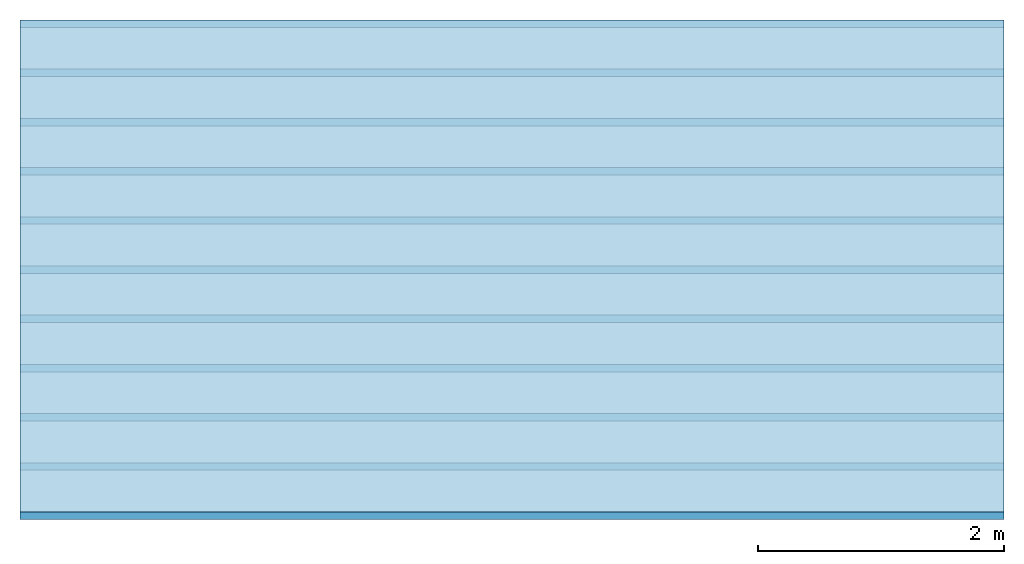
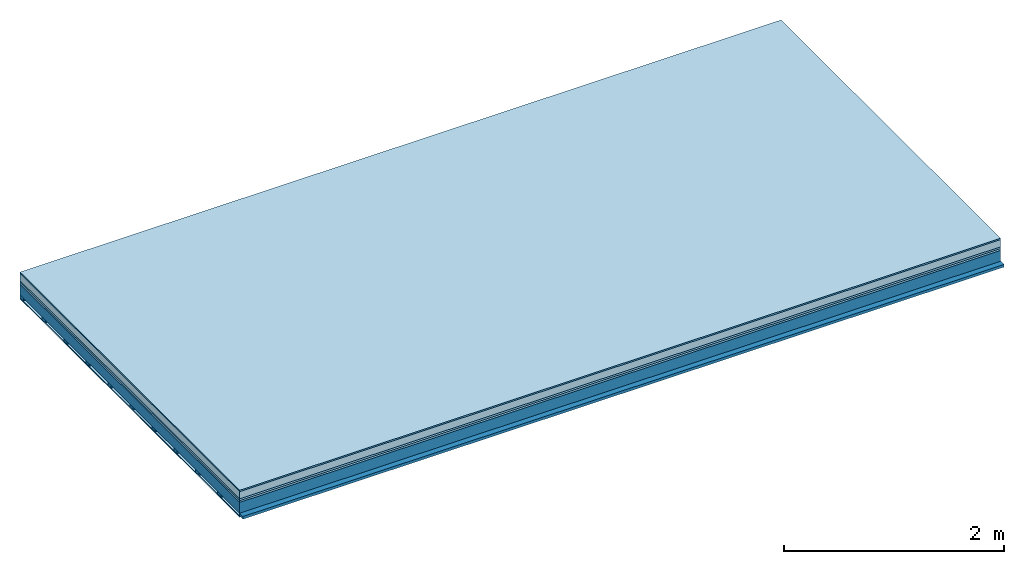
# One storey: 6 plates, 2 members, 1 element without a shape of its own.
"""IFC4 building model written with IfcOpenShell, lengths in metres."""

from ifc_helpers import new_model, si_unit, derived_unit, direction, frame, frame_2d, origin, origin_with_axes, place, context, project, spatial, rectangle, extrude, material, layer, layer_set, type_object, element, aggregate, save


model = new_model("IFC4")

# Units and contexts
plan_context = context("Plan", 3, precision=1e-05, world=origin(), true_north=direction((0.0, 1.0)))
model_context = context("Model", 3, precision=1e-05, world=origin(), true_north=direction((0.0, 1.0)))
ifc_project = project(units=[si_unit("LENGTHUNIT", "METRE"), derived_unit("SOUNDPRESSUREUNIT", [(si_unit("PRESSUREUNIT", "PASCAL", prefix="MICRO"), 0)]), si_unit("ENERGYUNIT", "JOULE", prefix="MEGA"), si_unit("MASSUNIT", "GRAM", prefix="KILO"), derived_unit("THERMALTRANSMITTANCEUNIT", [(si_unit("POWERUNIT", "WATT"), 1), (si_unit("AREAUNIT", "SQUARE_METRE"), -1), (si_unit("THERMODYNAMICTEMPERATUREUNIT", "KELVIN"), -1)]), derived_unit("AREADENSITYUNIT", [(si_unit("MASSUNIT", "GRAM", prefix="KILO"), 1), (si_unit("AREAUNIT", "SQUARE_METRE"), -1)]), derived_unit("USERDEFINED", [(si_unit("ENERGYUNIT", "JOULE", prefix="MEGA"), 1), (si_unit("AREAUNIT", "SQUARE_METRE"), -1)])], contexts=[plan_context, model_context])

# Site, building, storey
site = spatial("IfcSite", under=ifc_project)
building_placement = place(None, origin())
building = spatial("IfcBuilding", under=site, at=building_placement)
storey_placement = place(building_placement, origin())
storey = spatial("IfcBuildingStorey", under=building, at=storey_placement)

# Slab, members, plates
ifc_material_1 = material(Category="11.013")
ifc_layer_1 = layer(ifc_material_1, 0.015, Name="Flooring")
ifc_material_2 = material(Name="Cement screed", Category="04.006")
ifc_layer_2 = layer(ifc_material_2, 0.08, Name="On-material")
ifc_material_3 = material(Name="Wood fiber generic product", Category="10.009")
ifc_layer_3 = layer(ifc_material_3, 0.02, Name="Impact sound insulation")
ifc_material_4 = material(Category="10.004")
ifc_layer_4 = layer(ifc_material_4, 0.02, Name="Additional insulation")
ifc_material_5 = material(Name="no composite action")
ifc_layer_5 = layer(ifc_material_5, 0.0, Name="Bond")
ifc_layer_6 = layer(None, 0.12, Name="Supporting structure")
ifc_material_6 = material(Name="of the art")
ifc_layer_7 = layer(ifc_material_6, 0.0, Name="Bond")
ifc_layer_8 = layer(None, 0.03, Name="Battens / profiles")
ifc_material_7 = material(Name="Plasterboard type A", Category="03.008")
ifc_layer_9 = layer(ifc_material_7, 0.0125, Name="Ceiling covering 1st layer")
ifc_material_8 = material(Category="04.001")
ifc_layer_10 = layer(ifc_material_8, 0.003, Name="Surface / treatment")
ifc_layer_set = layer_set([ifc_layer_1, ifc_layer_2, ifc_layer_3, ifc_layer_4, ifc_layer_5, ifc_layer_6, ifc_layer_7, ifc_layer_8, ifc_layer_9, ifc_layer_10])
slab_type = type_object("IfcSlabType", Name="A2141", PredefinedType="NOTDEFINED", material=ifc_layer_set)
slab_placement = place(None, frame((0.0, 0.0, 0.0), z_axis=(0.0, 0.0, -1.0), x_axis=(1.0, 0.0, 0.0)))
slab = element("IfcSlab", 1, at=slab_placement, inside=storey, type_object=slab_type, material=ifc_layer_set, Name="Slab #1")
ifc_material_9 = material(Name="Solid timber panel")
member_1_placement = place(slab_placement, origin())
member_1 = element("IfcMember", 2, at=member_1_placement, material=ifc_material_9, Name="Supporting structure", context=plan_context, shape_type="SweptSolid", body=[
    extrude(rectangle(XDim=1.0, YDim=0.12, at=frame_2d((0.5, 0.06), x_axis=(1.0, 0.0))), frame((0.0, 4.0, 0.135), z_axis=(0.0, -1.0, 0.0), x_axis=(1.0, 0.0, 0.0)), (0.0, 0.0, 1.0), 4.0),
    extrude(rectangle(XDim=1.0, YDim=0.12, at=frame_2d((0.5, 0.06), x_axis=(1.0, 0.0))), frame((1.0, 4.0, 0.135), z_axis=(0.0, -1.0, 0.0), x_axis=(1.0, 0.0, 0.0)), (0.0, 0.0, 1.0), 4.0),
    extrude(rectangle(XDim=1.0, YDim=0.12, at=frame_2d((0.5, 0.06), x_axis=(1.0, 0.0))), frame((2.0, 4.0, 0.135), z_axis=(0.0, -1.0, 0.0), x_axis=(1.0, 0.0, 0.0)), (0.0, 0.0, 1.0), 4.0),
    extrude(rectangle(XDim=1.0, YDim=0.12, at=frame_2d((0.5, 0.06), x_axis=(1.0, 0.0))), frame((3.0, 4.0, 0.135), z_axis=(0.0, -1.0, 0.0), x_axis=(1.0, 0.0, 0.0)), (0.0, 0.0, 1.0), 4.0),
    extrude(rectangle(XDim=1.0, YDim=0.12, at=frame_2d((0.5, 0.06), x_axis=(1.0, 0.0))), frame((4.0, 4.0, 0.135), z_axis=(0.0, -1.0, 0.0), x_axis=(1.0, 0.0, 0.0)), (0.0, 0.0, 1.0), 4.0),
    extrude(rectangle(XDim=1.0, YDim=0.12, at=frame_2d((0.5, 0.06), x_axis=(1.0, 0.0))), frame((5.0, 4.0, 0.135), z_axis=(0.0, -1.0, 0.0), x_axis=(1.0, 0.0, 0.0)), (0.0, 0.0, 1.0), 4.0),
    extrude(rectangle(XDim=1.0, YDim=0.12, at=frame_2d((0.5, 0.06), x_axis=(1.0, 0.0))), frame((6.0, 4.0, 0.135), z_axis=(0.0, -1.0, 0.0), x_axis=(1.0, 0.0, 0.0)), (0.0, 0.0, 1.0), 4.0),
    extrude(rectangle(XDim=1.0, YDim=0.12, at=frame_2d((0.5, 0.06), x_axis=(1.0, 0.0))), frame((7.0, 4.0, 0.135), z_axis=(0.0, -1.0, 0.0), x_axis=(1.0, 0.0, 0.0)), (0.0, 0.0, 1.0), 4.0),
])
ifc_material_10 = material()
member_2_placement = place(slab_placement, origin())
member_2 = element("IfcMember", 3, at=member_2_placement, material=ifc_material_10, Name="Battens / profiles", context=plan_context, shape_type="SweptSolid", body=[
    extrude(rectangle(XDim=0.06, YDim=0.03, at=frame_2d((0.03, 0.015), x_axis=(1.0, 0.0))), frame((0.0, 0.0, 0.255), z_axis=(1.0, 0.0, 0.0), x_axis=(0.0, 1.0, 0.0)), (0.0, 0.0, 1.0), 8.0),
    extrude(rectangle(XDim=0.06, YDim=0.03, at=frame_2d((0.03, 0.015), x_axis=(1.0, 0.0))), frame((0.0, 0.4, 0.255), z_axis=(1.0, 0.0, 0.0), x_axis=(0.0, 1.0, 0.0)), (0.0, 0.0, 1.0), 8.0),
    extrude(rectangle(XDim=0.06, YDim=0.03, at=frame_2d((0.03, 0.015), x_axis=(1.0, 0.0))), frame((0.0, 0.8, 0.255), z_axis=(1.0, 0.0, 0.0), x_axis=(0.0, 1.0, 0.0)), (0.0, 0.0, 1.0), 8.0),
    extrude(rectangle(XDim=0.06, YDim=0.03, at=frame_2d((0.03, 0.015), x_axis=(1.0, 0.0))), frame((0.0, 1.2, 0.255), z_axis=(1.0, 0.0, 0.0), x_axis=(0.0, 1.0, 0.0)), (0.0, 0.0, 1.0), 8.0),
    extrude(rectangle(XDim=0.06, YDim=0.03, at=frame_2d((0.03, 0.015), x_axis=(1.0, 0.0))), frame((0.0, 1.6, 0.255), z_axis=(1.0, 0.0, 0.0), x_axis=(0.0, 1.0, 0.0)), (0.0, 0.0, 1.0), 8.0),
    extrude(rectangle(XDim=0.06, YDim=0.03, at=frame_2d((0.03, 0.015), x_axis=(1.0, 0.0))), frame((0.0, 2.0, 0.255), z_axis=(1.0, 0.0, 0.0), x_axis=(0.0, 1.0, 0.0)), (0.0, 0.0, 1.0), 8.0),
    extrude(rectangle(XDim=0.06, YDim=0.03, at=frame_2d((0.03, 0.015), x_axis=(1.0, 0.0))), frame((0.0, 2.4, 0.255), z_axis=(1.0, 0.0, 0.0), x_axis=(0.0, 1.0, 0.0)), (0.0, 0.0, 1.0), 8.0),
    extrude(rectangle(XDim=0.06, YDim=0.03, at=frame_2d((0.03, 0.015), x_axis=(1.0, 0.0))), frame((0.0, 2.8, 0.255), z_axis=(1.0, 0.0, 0.0), x_axis=(0.0, 1.0, 0.0)), (0.0, 0.0, 1.0), 8.0),
    extrude(rectangle(XDim=0.06, YDim=0.03, at=frame_2d((0.03, 0.015), x_axis=(1.0, 0.0))), frame((0.0, 3.2, 0.255), z_axis=(1.0, 0.0, 0.0), x_axis=(0.0, 1.0, 0.0)), (0.0, 0.0, 1.0), 8.0),
    extrude(rectangle(XDim=0.06, YDim=0.03, at=frame_2d((0.03, 0.015), x_axis=(1.0, 0.0))), frame((0.0, 3.6, 0.255), z_axis=(1.0, 0.0, 0.0), x_axis=(0.0, 1.0, 0.0)), (0.0, 0.0, 1.0), 8.0),
    extrude(rectangle(XDim=0.06, YDim=0.03, at=frame_2d((0.03, 0.015), x_axis=(1.0, 0.0))), frame((0.0, 4.0, 0.255), z_axis=(1.0, 0.0, 0.0), x_axis=(0.0, 1.0, 0.0)), (0.0, 0.0, 1.0), 8.0),
])
plate_1_placement = place(slab_placement, origin())
plate_1 = element("IfcPlate", 4, at=plate_1_placement, material=ifc_material_1, Name="Flooring", context=plan_context, shape_type="SweptSolid", body=[
    extrude(rectangle(XDim=8.0, YDim=4.0, at=frame_2d((4.0, 2.0), x_axis=(1.0, 0.0))), origin_with_axes(), (0.0, 0.0, 1.0), 0.015),
])
plate_2_placement = place(slab_placement, origin())
plate_2 = element("IfcPlate", 5, at=plate_2_placement, material=ifc_material_2, Name="On-material", context=plan_context, shape_type="SweptSolid", body=[
    extrude(rectangle(XDim=8.0, YDim=4.0, at=frame_2d((4.0, 2.0), x_axis=(1.0, 0.0))), frame((0.0, 0.0, 0.015), z_axis=(0.0, 0.0, 1.0), x_axis=(1.0, 0.0, 0.0)), (0.0, 0.0, 1.0), 0.08),
])
plate_3_placement = place(slab_placement, origin())
plate_3 = element("IfcPlate", 6, at=plate_3_placement, material=ifc_material_3, Name="Impact sound insulation", context=plan_context, shape_type="SweptSolid", body=[
    extrude(rectangle(XDim=8.0, YDim=4.0, at=frame_2d((4.0, 2.0), x_axis=(1.0, 0.0))), frame((0.0, 0.0, 0.095), z_axis=(0.0, 0.0, 1.0), x_axis=(1.0, 0.0, 0.0)), (0.0, 0.0, 1.0), 0.02),
])
plate_4_placement = place(slab_placement, origin())
plate_4 = element("IfcPlate", 7, at=plate_4_placement, material=ifc_material_4, Name="Additional insulation", context=plan_context, shape_type="SweptSolid", body=[
    extrude(rectangle(XDim=8.0, YDim=4.0, at=frame_2d((4.0, 2.0), x_axis=(1.0, 0.0))), frame((0.0, 0.0, 0.115), z_axis=(0.0, 0.0, 1.0), x_axis=(1.0, 0.0, 0.0)), (0.0, 0.0, 1.0), 0.02),
])
plate_5_placement = place(slab_placement, origin())
plate_5 = element("IfcPlate", 8, at=plate_5_placement, material=ifc_material_7, Name="Ceiling covering 1st layer", context=plan_context, shape_type="SweptSolid", body=[
    extrude(rectangle(XDim=8.0, YDim=4.0, at=frame_2d((4.0, 2.0), x_axis=(1.0, 0.0))), frame((0.0, 0.0, 0.285), z_axis=(0.0, 0.0, 1.0), x_axis=(1.0, 0.0, 0.0)), (0.0, 0.0, 1.0), 0.0125),
])
plate_6_placement = place(slab_placement, origin())
plate_6 = element("IfcPlate", 9, at=plate_6_placement, material=ifc_material_8, Name="Surface / treatment", context=plan_context, shape_type="SweptSolid", body=[
    extrude(rectangle(XDim=8.0, YDim=4.0, at=frame_2d((4.0, 2.0), x_axis=(1.0, 0.0))), frame((0.0, 0.0, 0.2975), z_axis=(0.0, 0.0, 1.0), x_axis=(1.0, 0.0, 0.0)), (0.0, 0.0, 1.0), 0.003),
])
aggregate(slab, [plate_1, plate_2, plate_3, plate_4, member_1, member_2, plate_5, plate_6])

save(model, "model.ifc")
